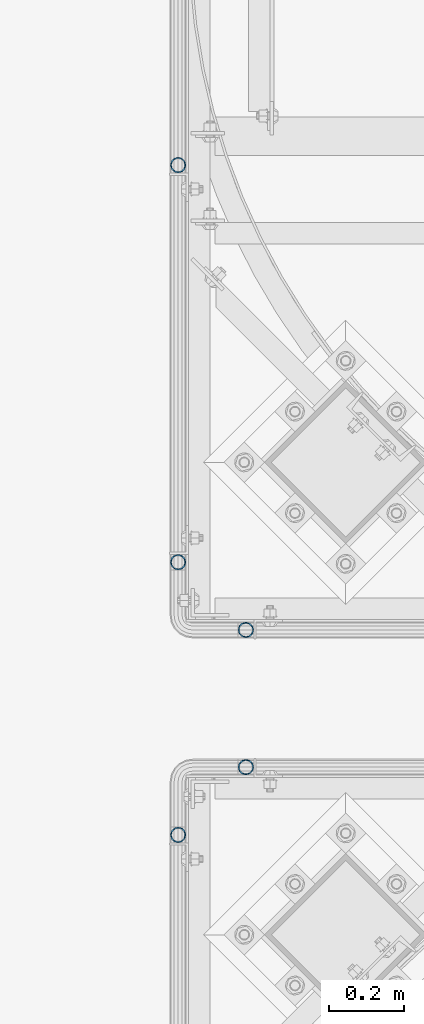
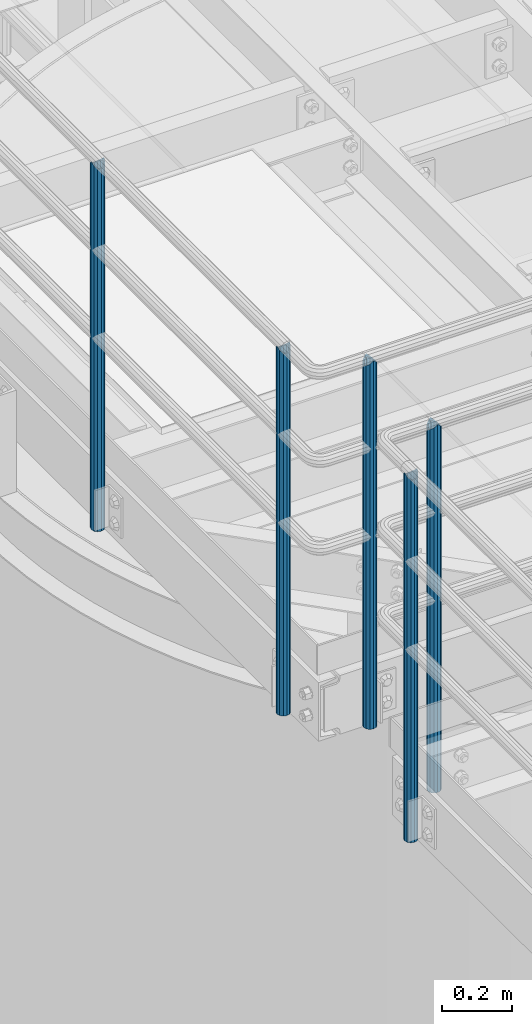
# One storey, part 547 of 1876: 5 columns, 4 elements without a shape of their own.
"""IFC2X3 building model written with IfcOpenShell, lengths in millimetres."""

from ifc_helpers import new_model, si_unit, frame, origin_with_axes, place, context, subcontext, project, spatial, faceted_brep, material, type_object, element, aggregate, save


model = new_model("IFC2X3")

# Units and contexts
model_context = context("Model", 3, precision=1e-05, world=origin_with_axes())
body_context = subcontext(model_context, "Body", "Model", "MODEL_VIEW")
ifc_project = project(units=[si_unit("LENGTHUNIT", "METRE", prefix="MILLI"), si_unit("AREAUNIT", "SQUARE_METRE"), si_unit("VOLUMEUNIT", "CUBIC_METRE"), si_unit("MASSUNIT", "GRAM", prefix="KILO"), si_unit("TIMEUNIT", "SECOND"), si_unit("PLANEANGLEUNIT", "RADIAN"), si_unit("SOLIDANGLEUNIT", "STERADIAN"), si_unit("THERMODYNAMICTEMPERATUREUNIT", "DEGREE_CELSIUS"), si_unit("LUMINOUSINTENSITYUNIT", "LUMEN")], contexts=[model_context])

# Site, building, storey
site_placement = place(None, origin_with_axes())
site = spatial("IfcSite", under=ifc_project, at=site_placement, CompositionType="ELEMENT")
building_placement = place(site_placement, origin_with_axes())
building = spatial("IfcBuilding", under=site, at=building_placement, Name="Undefined", CompositionType="ELEMENT")
storey_placement = place(building_placement, origin_with_axes())
storey = spatial("IfcBuildingStorey", under=building, at=storey_placement, Name="Undefined", CompositionType="ELEMENT", Elevation=0.0)

# Assembly, column
assembly_1_placement = place(storey_placement, origin_with_axes())
assembly_1 = element("IfcElementAssembly", 1, at=assembly_1_placement, inside=storey, Name="HANDRAIL", AssemblyPlace="NOTDEFINED", PredefinedType="RIGID_FRAME")
ifc_material = material()
column_type = type_object("IfcColumnType", Name="PIPE1-1/4STD", PredefinedType="NOTDEFINED")
column_1_placement = place(assembly_1_placement, frame((3517.90474593762, -11381.1963554687, 7813.675), z_axis=(0.0, 1.0, 0.0), x_axis=(0.0, 0.0, 1.0)))
column_1 = element("IfcColumn", 2, at=column_1_placement, type_object=column_type, material=ifc_material, Name="POST", ObjectType="PIPE1-1/4STD", context=body_context, shape_type="Brep", body=[
    faceted_brep([(1276.35, 0.0, -21.0820000000003), (1265.809, 10.5410000000002, -18.2575475625836), (1265.809, -10.5410000000002, -18.2575475625836), (1257.61603877328, 15.1779612267264, 8.76299999999992), (1255.268, 17.5259999999998, 0.0), (1255.268, 21.0820000000003, 0.0), (1258.09245243742, 18.2575475625836, 10.5410000000002), (1258.09245243742, 13.3999612267262, 10.5410000000002), (1258.09245243742, 13.3999612267262, -10.5410000000002), (1258.09245243742, 18.2575475625836, -10.5410000000002), (1257.61603877328, 15.1779612267264, -8.76299999999992), (1262.72937633681, 8.76299999999992, -15.1779612267255), (1265.07741511008, 0.0, -17.5259999999998), (1262.72937633681, -8.76299999999992, -15.1779612267255), (1258.09245243741, -13.3999612267244, -10.541000000002), (1258.09245243742, -18.2575475625836, -10.5409999999993), (1257.61602877145, -15.1779612267264, -8.76300000000083), (1255.268, -17.5259999999998, 0.0), (1255.268, -21.0820000000003, 0.0), (1257.61604877511, -15.1779612267264, 8.76300000000083), (1258.09245243741, -13.399961226728, 10.5409999999983), (1258.09245243742, -18.2575475625836, 10.5409999999993), (1276.35, 0.0, 21.0820000000003), (1265.809, -10.5410000000002, 18.2575475625836), (1265.809, 10.5410000000002, 18.2575475625836), (1262.72941366414, -8.76299999999992, 15.1779612267264), (1265.07745243742, 0.0, 17.5259999999998), (1262.72941366414, 8.76299999999992, 15.1779612267264), (0.0, -18.2575475625836, -10.5409999999993), (0.0, -10.5410000000002, -18.2575475625836), (-4.28826751885936e-09, 0.0, -21.0820000000003), (0.0, 10.5410000000002, -18.2575475625836), (0.0, 18.2575475625836, -10.5409999999993), (9.09494701772928e-13, 21.0820000000003, 0.0), (0.0, 18.2575475625836, 10.5409999999993), (0.0, 10.5410000000002, 18.2575475625836), (0.0, 0.0, 21.0820000000003), (0.0, -18.2575475625836, 10.5409999999993), (9.09494701772928e-13, -21.0820000000003, 0.0), (0.0, -10.5410000000002, 18.2575475625836), (0.0, -15.1779612267264, -8.76300000000083), (0.0, -8.76299999999992, -15.1779612267255), (0.0, 0.0, -17.5259999999998), (0.0, 8.76299999999992, -15.1779612267255), (0.0, 15.1779612267264, -8.76300000000083), (0.0, 17.5259999999998, 0.0), (0.0, 15.1779612267264, 8.76300000000083), (0.0, 8.76299999999992, 15.1779612267255), (0.0, 0.0, 17.5259999999998), (0.0, -8.76299999999992, 15.1779612267255), (0.0, -15.1779612267264, 8.76300000000083), (0.0, -17.5259999999998, 0.0)], [[[0, 1, 2]], [[3, 4, 5, 6, 7]], [[8, 9, 5, 4, 10]], [[2, 1, 9, 8, 11, 12, 13, 14, 15]], [[15, 14, 16, 17, 18]], [[18, 17, 19, 20, 21]], [[22, 23, 24]], [[21, 20, 25, 26, 27, 7, 6, 24, 23]], [[28, 29, 2, 15]], [[29, 30, 0, 2]], [[30, 31, 1, 0]], [[31, 32, 9, 1]], [[32, 33, 5, 9]], [[33, 34, 6, 5]], [[34, 35, 24, 6]], [[35, 36, 22, 24]], [[37, 38, 18, 21]], [[39, 37, 21, 23]], [[36, 39, 23, 22]], [[38, 28, 15, 18]], [[37, 39, 36, 35, 34, 33, 32, 31, 30, 29, 28, 38], [40, 41, 42, 43, 44, 45, 46, 47, 48, 49, 50, 51]], [[49, 48, 26, 25]], [[19, 50, 49, 25, 20]], [[51, 50, 19, 17]], [[40, 51, 17, 16]], [[41, 40, 16, 14, 13]], [[42, 41, 13, 12]], [[43, 42, 12, 11]], [[10, 44, 43, 11, 8]], [[45, 44, 10, 4]], [[46, 45, 4, 3]], [[47, 46, 3, 7, 27]], [[48, 47, 27, 26]]]),
])
aggregate(assembly_1, [column_1])

# Assembly, columns
assembly_2_placement = place(storey_placement, origin_with_axes())
assembly_2 = element("IfcElementAssembly", 3, at=assembly_2_placement, inside=storey, Name="HANDRAIL", AssemblyPlace="NOTDEFINED", PredefinedType="RIGID_FRAME")
column_2_placement = place(assembly_2_placement, frame((3338.07274593762, -10147.2643554687, 7813.675), z_axis=(0.0, 1.0, 0.0), x_axis=(0.0, 0.0, 1.0)))
column_2 = element("IfcColumn", 4, at=column_2_placement, type_object=column_type, material=ifc_material, Name="POST", ObjectType="PIPE1-1/4STD", context=body_context, shape_type="Brep", body=[
    faceted_brep([(1258.09245243742, -10.5410000000002, 18.2575475625836), (1258.09245243742, -10.5410017746963, 13.3999594520301), (1257.61603823465, -8.76299999999992, 15.1779612267255), (1255.268, 0.0, 17.5259999999998), (1255.268, 0.0, 21.0820000000003), (1257.6160393119, 8.76299999999992, 15.1779612267255), (1258.09245243742, 10.5409982253032, 13.3999630014223), (1258.09245243742, 10.5410000000002, 18.2575475625836), (1276.35, 21.0820000000003, 0.0), (1265.809, 18.2575475625836, 10.5410000000002), (1265.809, 18.2575475625836, -10.5410000000002), (1262.72941482472, 15.1779612267264, 8.76300000000083), (1265.07745243742, 17.5259999999998, 0.0), (1262.72941250358, 15.1779612267264, -8.76300000000083), (1258.09245243742, 10.5410000000002, -13.3999612267253), (1258.09245243742, 10.5410000000002, -18.2575475625836), (1257.61603877328, 8.76299999999992, -15.1779612267255), (1255.268, 0.0, -17.5259999999998), (1255.268, 0.0, -21.0820000000003), (1258.09245243742, -10.5410000000002, -13.3999612267253), (1258.09245243742, -10.5410000000002, -18.2575475625836), (1257.61603877328, -8.76299999999992, -15.1779612267255), (1276.35000278283, -21.0820000000003, 0.0), (1265.809, -18.2575475625836, -10.5410000000002), (1265.809, -18.2575475625836, 10.5410000000002), (1262.72941366414, -15.1779612267264, -8.76300000000083), (1265.07745243742, -17.5259999999998, 0.0), (1262.72941366414, -15.1779612267264, 8.76300000000083), (0.0, -18.2575475625836, -10.5409999999993), (0.0, -10.5410000000002, -18.2575475625836), (-4.28826751885936e-09, 0.0, -21.0820000000003), (0.0, 10.5410000000002, -18.2575475625836), (0.0, 18.2575475625836, -10.5409999999993), (9.09494701772928e-13, 21.0820000000003, 0.0), (0.0, 18.2575475625836, 10.5409999999993), (0.0, 10.5410000000002, 18.2575475625836), (0.0, 0.0, 21.0820000000003), (0.0, -10.5410000000002, 18.2575475625836), (0.0, -18.2575475625836, 10.5409999999993), (9.09494701772928e-13, -21.0820000000003, 0.0), (0.0, -15.1779612267264, -8.76300000000083), (0.0, -8.76299999999992, -15.1779612267255), (0.0, 0.0, -17.5259999999998), (0.0, 8.76299999999992, -15.1779612267255), (0.0, 15.1779612267264, -8.76300000000083), (0.0, 17.5259999999998, 0.0), (0.0, 15.1779612267264, 8.76300000000083), (0.0, 8.76299999999992, 15.1779612267255), (0.0, 0.0, 17.5259999999998), (0.0, -8.76299999999992, 15.1779612267255), (0.0, -15.1779612267264, 8.76300000000083), (0.0, -17.5259999999998, 0.0)], [[[0, 1, 2, 3, 4]], [[4, 3, 5, 6, 7]], [[8, 9, 10]], [[7, 6, 11, 12, 13, 14, 15, 10, 9]], [[16, 17, 18, 15, 14]], [[19, 20, 18, 17, 21]], [[22, 23, 24]], [[24, 23, 20, 19, 25, 26, 27, 1, 0]], [[28, 29, 20, 23]], [[29, 30, 18, 20]], [[30, 31, 15, 18]], [[31, 32, 10, 15]], [[32, 33, 8, 10]], [[33, 34, 9, 8]], [[34, 35, 7, 9]], [[35, 36, 4, 7]], [[36, 37, 0, 4]], [[37, 38, 24, 0]], [[38, 39, 22, 24]], [[39, 28, 23, 22]], [[38, 37, 36, 35, 34, 33, 32, 31, 30, 29, 28, 39], [40, 41, 42, 43, 44, 45, 46, 47, 48, 49, 50, 51]], [[40, 51, 26, 25]], [[21, 41, 40, 25, 19]], [[42, 41, 21, 17]], [[43, 42, 17, 16]], [[44, 43, 16, 14, 13]], [[45, 44, 13, 12]], [[46, 45, 12, 11]], [[5, 47, 46, 11, 6]], [[48, 47, 5, 3]], [[49, 48, 3, 2]], [[50, 49, 2, 1, 27]], [[51, 50, 27, 26]]]),
])
column_3_placement = place(assembly_2_placement, frame((3338.07274593762, -11201.3643554687, 7813.675), z_axis=(0.0, 1.0, 0.0), x_axis=(0.0, 0.0, 1.0)))
column_3 = element("IfcColumn", 5, at=column_3_placement, type_object=column_type, material=ifc_material, Name="POST", ObjectType="PIPE1-1/4STD", context=body_context, shape_type="Brep", body=[
    faceted_brep([(1258.09245243742, -10.5410000000002, 18.2575475625836), (1258.09245243742, -10.5410017746963, 13.3999594520301), (1257.61603823465, -8.76299999999992, 15.1779612267255), (1255.268, 0.0, 17.5259999999998), (1255.268, 0.0, 21.0820000000003), (1257.6160393119, 8.76299999999992, 15.1779612267255), (1258.09245243742, 10.5409982253032, 13.3999630014223), (1258.09245243742, 10.5410000000002, 18.2575475625836), (1276.35, 21.0820000000003, 0.0), (1265.809, 18.2575475625836, 10.5410000000002), (1265.809, 18.2575475625836, -10.5410000000002), (1262.72941482472, 15.1779612267264, 8.76300000000083), (1265.07745243742, 17.5259999999998, 0.0), (1262.72941250358, 15.1779612267264, -8.76300000000083), (1258.09245243742, 10.5410000000002, -13.3999612267253), (1258.09245243742, 10.5410000000002, -18.2575475625836), (1257.61603877328, 8.76299999999992, -15.1779612267255), (1255.268, 0.0, -17.5259999999998), (1255.268, 0.0, -21.0820000000003), (1258.09245243742, -10.5410000000002, -13.3999612267253), (1258.09245243742, -10.5410000000002, -18.2575475625836), (1257.61603877328, -8.76299999999992, -15.1779612267255), (1276.35000278283, -21.0820000000003, 0.0), (1265.809, -18.2575475625836, -10.5410000000002), (1265.809, -18.2575475625836, 10.5410000000002), (1262.72941366414, -15.1779612267264, -8.76300000000083), (1265.07745243742, -17.5259999999998, 0.0), (1262.72941366414, -15.1779612267264, 8.76300000000083), (0.0, -18.2575475625836, -10.5409999999993), (0.0, -10.5410000000002, -18.2575475625836), (-4.28826751885936e-09, 0.0, -21.0820000000003), (0.0, 10.5410000000002, -18.2575475625836), (0.0, 18.2575475625836, -10.5409999999993), (9.09494701772928e-13, 21.0820000000003, 0.0), (0.0, 18.2575475625836, 10.5409999999993), (0.0, 10.5410000000002, 18.2575475625836), (0.0, 0.0, 21.0820000000003), (0.0, -10.5410000000002, 18.2575475625836), (0.0, -18.2575475625836, 10.5409999999993), (9.09494701772928e-13, -21.0820000000003, 0.0), (0.0, -15.1779612267264, -8.76300000000083), (0.0, -8.76299999999992, -15.1779612267255), (0.0, 0.0, -17.5259999999998), (0.0, 8.76299999999992, -15.1779612267255), (0.0, 15.1779612267264, -8.76300000000083), (0.0, 17.5259999999998, 0.0), (0.0, 15.1779612267264, 8.76300000000083), (0.0, 8.76299999999992, 15.1779612267255), (0.0, 0.0, 17.5259999999998), (0.0, -8.76299999999992, 15.1779612267255), (0.0, -15.1779612267264, 8.76300000000083), (0.0, -17.5259999999998, 0.0)], [[[0, 1, 2, 3, 4]], [[4, 3, 5, 6, 7]], [[8, 9, 10]], [[7, 6, 11, 12, 13, 14, 15, 10, 9]], [[16, 17, 18, 15, 14]], [[19, 20, 18, 17, 21]], [[22, 23, 24]], [[24, 23, 20, 19, 25, 26, 27, 1, 0]], [[28, 29, 20, 23]], [[29, 30, 18, 20]], [[30, 31, 15, 18]], [[31, 32, 10, 15]], [[32, 33, 8, 10]], [[33, 34, 9, 8]], [[34, 35, 7, 9]], [[35, 36, 4, 7]], [[36, 37, 0, 4]], [[37, 38, 24, 0]], [[38, 39, 22, 24]], [[39, 28, 23, 22]], [[38, 37, 36, 35, 34, 33, 32, 31, 30, 29, 28, 39], [40, 41, 42, 43, 44, 45, 46, 47, 48, 49, 50, 51]], [[40, 51, 26, 25]], [[21, 41, 40, 25, 19]], [[42, 41, 21, 17]], [[43, 42, 17, 16]], [[44, 43, 16, 14, 13]], [[45, 44, 13, 12]], [[46, 45, 12, 11]], [[5, 47, 46, 11, 6]], [[48, 47, 5, 3]], [[49, 48, 3, 2]], [[50, 49, 2, 1, 27]], [[51, 50, 27, 26]]]),
])
aggregate(assembly_2, [column_2, column_3])

# Assembly, column
assembly_3_placement = place(storey_placement, origin_with_axes())
assembly_3 = element("IfcElementAssembly", 6, at=assembly_3_placement, inside=storey, Name="HANDRAIL", AssemblyPlace="NOTDEFINED", PredefinedType="RIGID_FRAME")
column_4_placement = place(assembly_3_placement, frame((3517.90143150122, -11745.4324531238, 7813.675), z_axis=(0.0, 1.0, 0.0), x_axis=(0.0, 0.0, 1.0)))
column_4 = element("IfcColumn", 7, at=column_4_placement, type_object=column_type, material=ifc_material, Name="POST", ObjectType="PIPE1-1/4STD", context=body_context, shape_type="Brep", body=[
    faceted_brep([(1276.35, 0.0, -21.0820000000003), (1265.809, 10.5410000000002, -18.2575475625836), (1265.809, -10.5410000000002, -18.2575475625836), (1257.61603877328, 15.1779612267264, 8.76299999999992), (1255.268, 17.5259999999998, 0.0), (1255.268, 21.0820000000003, 0.0), (1258.09245243742, 18.2575475625836, 10.5410000000002), (1258.09245243742, 13.3999612267262, 10.5410000000002), (1258.09245243742, 13.3999612267262, -10.5410000000002), (1258.09245243742, 18.2575475625836, -10.5410000000002), (1257.61603877328, 15.1779612267264, -8.76299999999992), (1262.72937633681, 8.76299999999992, -15.1779612267255), (1265.07741511008, 0.0, -17.5259999999998), (1262.72937633681, -8.76299999999992, -15.1779612267255), (1258.09245243741, -13.3999612267244, -10.541000000002), (1258.09245243742, -18.2575475625836, -10.5409999999993), (1257.61602877145, -15.1779612267264, -8.76300000000083), (1255.268, -17.5259999999998, 0.0), (1255.268, -21.0820000000003, 0.0), (1257.61604877511, -15.1779612267264, 8.76300000000083), (1258.09245243741, -13.399961226728, 10.5409999999983), (1258.09245243742, -18.2575475625836, 10.5409999999993), (1276.35, 0.0, 21.0820000000003), (1265.809, -10.5410000000002, 18.2575475625836), (1265.809, 10.5410000000002, 18.2575475625836), (1262.72941366414, -8.76299999999992, 15.1779612267264), (1265.07745243742, 0.0, 17.5259999999998), (1262.72941366414, 8.76299999999992, 15.1779612267264), (0.0, -18.2575475625836, -10.5409999999993), (0.0, -10.5410000000002, -18.2575475625836), (-4.28826751885936e-09, 0.0, -21.0820000000003), (0.0, 10.5410000000002, -18.2575475625836), (0.0, 18.2575475625836, -10.5409999999993), (9.09494701772928e-13, 21.0820000000003, 0.0), (0.0, 18.2575475625836, 10.5409999999993), (0.0, 10.5410000000002, 18.2575475625836), (0.0, 0.0, 21.0820000000003), (0.0, -18.2575475625836, 10.5409999999993), (9.09494701772928e-13, -21.0820000000003, 0.0), (0.0, -10.5410000000002, 18.2575475625836), (0.0, -15.1779612267264, -8.76300000000083), (0.0, -8.76299999999992, -15.1779612267255), (0.0, 0.0, -17.5259999999998), (0.0, 8.76299999999992, -15.1779612267255), (0.0, 15.1779612267264, -8.76300000000083), (0.0, 17.5259999999998, 0.0), (0.0, 15.1779612267264, 8.76300000000083), (0.0, 8.76299999999992, 15.1779612267255), (0.0, 0.0, 17.5259999999998), (0.0, -8.76299999999992, 15.1779612267255), (0.0, -15.1779612267264, 8.76300000000083), (0.0, -17.5259999999998, 0.0)], [[[0, 1, 2]], [[3, 4, 5, 6, 7]], [[8, 9, 5, 4, 10]], [[2, 1, 9, 8, 11, 12, 13, 14, 15]], [[15, 14, 16, 17, 18]], [[18, 17, 19, 20, 21]], [[22, 23, 24]], [[21, 20, 25, 26, 27, 7, 6, 24, 23]], [[28, 29, 2, 15]], [[29, 30, 0, 2]], [[30, 31, 1, 0]], [[31, 32, 9, 1]], [[32, 33, 5, 9]], [[33, 34, 6, 5]], [[34, 35, 24, 6]], [[35, 36, 22, 24]], [[37, 38, 18, 21]], [[39, 37, 21, 23]], [[36, 39, 23, 22]], [[38, 28, 15, 18]], [[37, 39, 36, 35, 34, 33, 32, 31, 30, 29, 28, 38], [40, 41, 42, 43, 44, 45, 46, 47, 48, 49, 50, 51]], [[49, 48, 26, 25]], [[19, 50, 49, 25, 20]], [[51, 50, 19, 17]], [[40, 51, 17, 16]], [[41, 40, 16, 14, 13]], [[42, 41, 13, 12]], [[43, 42, 12, 11]], [[10, 44, 43, 11, 8]], [[45, 44, 10, 4]], [[46, 45, 4, 3]], [[47, 46, 3, 7, 27]], [[48, 47, 27, 26]]]),
])
aggregate(assembly_3, [column_4])

assembly_4_placement = place(storey_placement, origin_with_axes())
assembly_4 = element("IfcElementAssembly", 8, at=assembly_4_placement, inside=storey, Name="HANDRAIL", AssemblyPlace="NOTDEFINED", PredefinedType="RIGID_FRAME")
column_5_placement = place(assembly_4_placement, frame((3338.06943150122, -11925.2644042969, 7813.675), z_axis=(0.0, 1.0, 0.0), x_axis=(0.0, 0.0, 1.0)))
column_5 = element("IfcColumn", 9, at=column_5_placement, type_object=column_type, material=ifc_material, Name="POST", ObjectType="PIPE1-1/4STD", context=body_context, shape_type="Brep", body=[
    faceted_brep([(1258.09245243742, -10.5410000000002, 18.2575475625836), (1258.09245243742, -10.5410017746963, 13.3999594520301), (1257.61603823465, -8.76299999999992, 15.1779612267255), (1255.268, 0.0, 17.5259999999998), (1255.268, 0.0, 21.0820000000003), (1257.6160393119, 8.76299999999992, 15.1779612267255), (1258.09245243742, 10.5409982253032, 13.3999630014223), (1258.09245243742, 10.5410000000002, 18.2575475625836), (1276.35, 21.0820000000003, 0.0), (1265.809, 18.2575475625836, 10.5410000000002), (1265.809, 18.2575475625836, -10.5410000000002), (1262.72941482472, 15.1779612267264, 8.76300000000083), (1265.07745243742, 17.5259999999998, 0.0), (1262.72941250358, 15.1779612267264, -8.76300000000083), (1258.09245243742, 10.5410000000002, -13.3999612267253), (1258.09245243742, 10.5410000000002, -18.2575475625836), (1257.61603877328, 8.76299999999992, -15.1779612267255), (1255.268, 0.0, -17.5259999999998), (1255.268, 0.0, -21.0820000000003), (1258.09245243742, -10.5410000000002, -13.3999612267253), (1258.09245243742, -10.5410000000002, -18.2575475625836), (1257.61603877328, -8.76299999999992, -15.1779612267255), (1276.35000278283, -21.0820000000003, 0.0), (1265.809, -18.2575475625836, -10.5410000000002), (1265.809, -18.2575475625836, 10.5410000000002), (1262.72941366414, -15.1779612267264, -8.76300000000083), (1265.07745243742, -17.5259999999998, 0.0), (1262.72941366414, -15.1779612267264, 8.76300000000083), (0.0, -18.2575475625836, -10.5409999999993), (0.0, -10.5410000000002, -18.2575475625836), (-4.28826751885936e-09, 0.0, -21.0820000000003), (0.0, 10.5410000000002, -18.2575475625836), (0.0, 18.2575475625836, -10.5409999999993), (9.09494701772928e-13, 21.0820000000003, 0.0), (0.0, 18.2575475625836, 10.5409999999993), (0.0, 10.5410000000002, 18.2575475625836), (0.0, 0.0, 21.0820000000003), (0.0, -10.5410000000002, 18.2575475625836), (0.0, -18.2575475625836, 10.5409999999993), (9.09494701772928e-13, -21.0820000000003, 0.0), (0.0, -15.1779612267264, -8.76300000000083), (0.0, -8.76299999999992, -15.1779612267255), (0.0, 0.0, -17.5259999999998), (0.0, 8.76299999999992, -15.1779612267255), (0.0, 15.1779612267264, -8.76300000000083), (0.0, 17.5259999999998, 0.0), (0.0, 15.1779612267264, 8.76300000000083), (0.0, 8.76299999999992, 15.1779612267255), (0.0, 0.0, 17.5259999999998), (0.0, -8.76299999999992, 15.1779612267255), (0.0, -15.1779612267264, 8.76300000000083), (0.0, -17.5259999999998, 0.0)], [[[0, 1, 2, 3, 4]], [[4, 3, 5, 6, 7]], [[8, 9, 10]], [[7, 6, 11, 12, 13, 14, 15, 10, 9]], [[16, 17, 18, 15, 14]], [[19, 20, 18, 17, 21]], [[22, 23, 24]], [[24, 23, 20, 19, 25, 26, 27, 1, 0]], [[28, 29, 20, 23]], [[29, 30, 18, 20]], [[30, 31, 15, 18]], [[31, 32, 10, 15]], [[32, 33, 8, 10]], [[33, 34, 9, 8]], [[34, 35, 7, 9]], [[35, 36, 4, 7]], [[36, 37, 0, 4]], [[37, 38, 24, 0]], [[38, 39, 22, 24]], [[39, 28, 23, 22]], [[38, 37, 36, 35, 34, 33, 32, 31, 30, 29, 28, 39], [40, 41, 42, 43, 44, 45, 46, 47, 48, 49, 50, 51]], [[40, 51, 26, 25]], [[21, 41, 40, 25, 19]], [[42, 41, 21, 17]], [[43, 42, 17, 16]], [[44, 43, 16, 14, 13]], [[45, 44, 13, 12]], [[46, 45, 12, 11]], [[5, 47, 46, 11, 6]], [[48, 47, 5, 3]], [[49, 48, 3, 2]], [[50, 49, 2, 1, 27]], [[51, 50, 27, 26]]]),
])
aggregate(assembly_4, [column_5])

save(model, "model.ifc")
